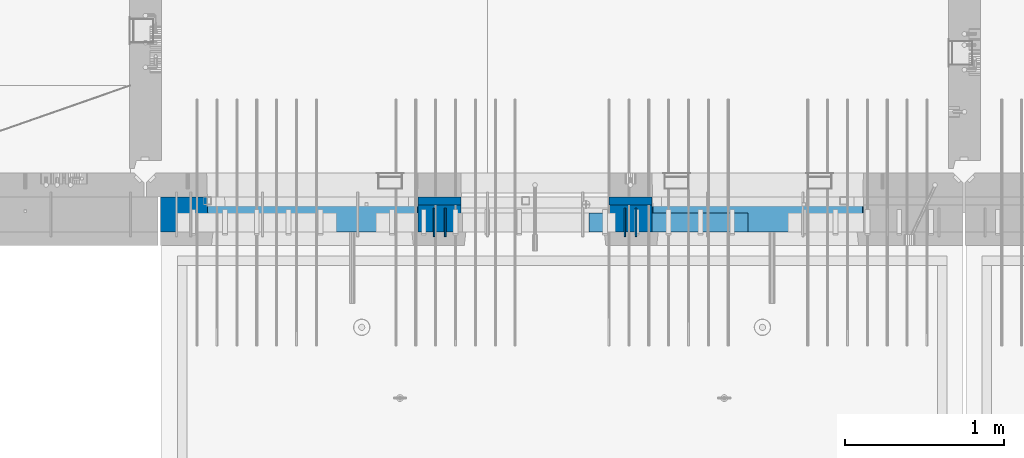
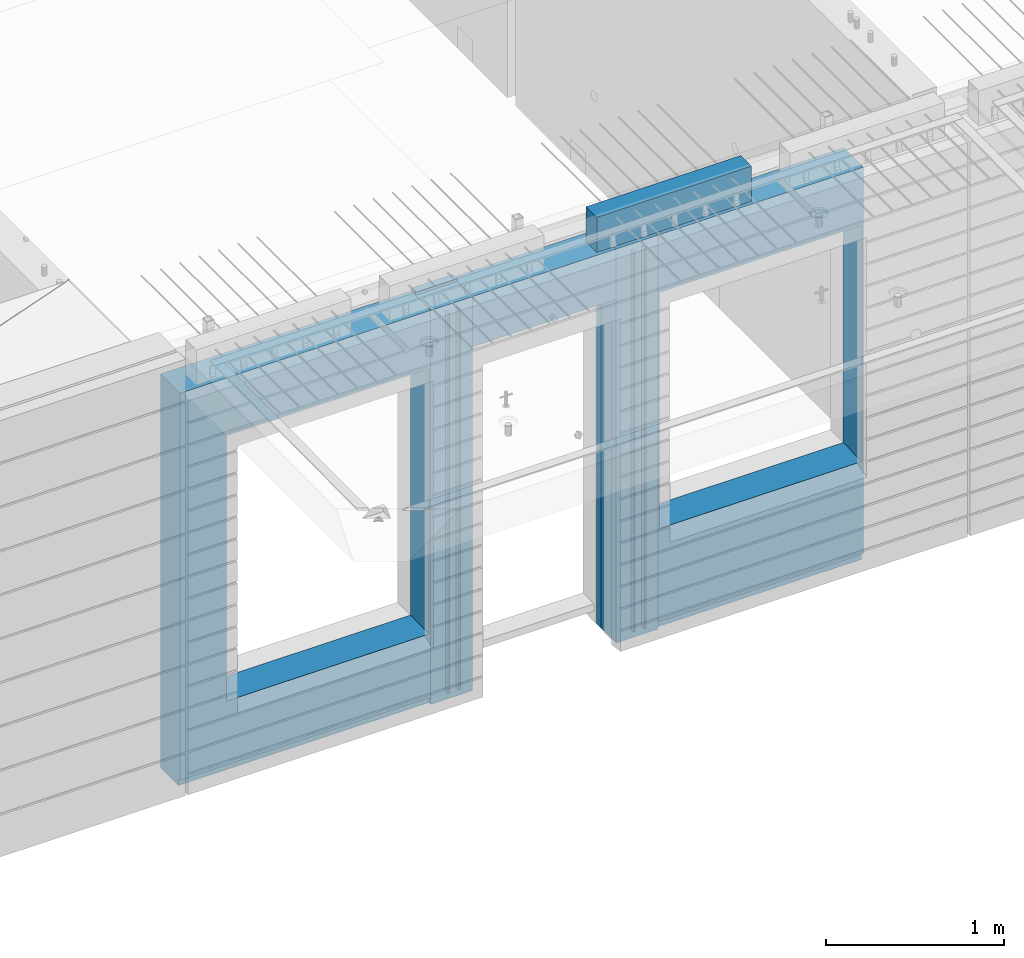
# One storey, part 219 of 334: 10 walls, 3 elements without a shape of their own.
"""IFC2X3 building model written with IfcOpenShell, lengths in millimetres."""

from ifc_helpers import new_model, si_unit, frame, origin_with_axes, place, context, subcontext, project, spatial, faceted_brep, material, type_object, element, aggregate, save


model = new_model("IFC2X3")

# Units and contexts
model_context = context("Model", 3, precision=1e-05, world=origin_with_axes())
body_context = subcontext(model_context, "Body", "Model", "MODEL_VIEW")
ifc_project = project(units=[si_unit("LENGTHUNIT", "METRE", prefix="MILLI"), si_unit("AREAUNIT", "SQUARE_METRE"), si_unit("VOLUMEUNIT", "CUBIC_METRE"), si_unit("MASSUNIT", "GRAM", prefix="KILO"), si_unit("TIMEUNIT", "SECOND"), si_unit("PLANEANGLEUNIT", "RADIAN"), si_unit("SOLIDANGLEUNIT", "STERADIAN"), si_unit("THERMODYNAMICTEMPERATUREUNIT", "DEGREE_CELSIUS"), si_unit("LUMINOUSINTENSITYUNIT", "LUMEN")], contexts=[model_context])

# Site, building, storey
site_placement = place(None, origin_with_axes())
site = spatial("IfcSite", under=ifc_project, at=site_placement, CompositionType="ELEMENT")
building_placement = place(site_placement, origin_with_axes())
building = spatial("IfcBuilding", under=site, at=building_placement, CompositionType="ELEMENT")
storey_placement = place(building_placement, origin_with_axes())
storey = spatial("IfcBuildingStorey", under=building, at=storey_placement, Name="3", CompositionType="ELEMENT", Elevation=0.0)

# Assembly, walls
assembly_1_placement = place(storey_placement, origin_with_axes())
assembly_1 = element("IfcElementAssembly", 1, at=assembly_1_placement, inside=storey, AssemblyPlace="NOTDEFINED", PredefinedType="REINFORCEMENT_UNIT")
ifc_material_1 = material(Name="Undefined")
wall_type_1 = type_object("IfcWallType", PredefinedType="NOTDEFINED")
wall_1_placement = place(assembly_1_placement, frame((18475.0, 7780.0, 89115.0), z_axis=(0.0, 0.0, 1.0), x_axis=(0.0, -1.0, 0.0)))
wall_1 = element("IfcWall", 2, at=wall_1_placement, type_object=wall_type_1, material=ifc_material_1, Name="(PD)", context=body_context, shape_type="Brep", body=[
    faceted_brep([(0.0, 5.0, -1300.0), (0.0, 5.0, 1300.0), (180.0, 5.0, 1300.0), (180.0, 5.0, -1300.0), (0.0, -5.0, 1300.0), (180.0, -5.0, 1300.0), (0.0, -5.0, -1300.0), (180.0, -5.0, -1300.0)], [[[0, 1, 2, 3]], [[1, 4, 5, 2]], [[4, 6, 7, 5]], [[6, 0, 3, 7]], [[5, 7, 3, 2]], [[6, 4, 1, 0]]]),
])
wall_2_placement = place(assembly_1_placement, frame((18545.0, 7780.0, 89115.0), z_axis=(0.0, 0.0, 1.0), x_axis=(0.0, -1.0, 0.0)))
wall_2 = element("IfcWall", 3, at=wall_2_placement, type_object=wall_type_1, material=ifc_material_1, Name="(PD)", context=body_context, shape_type="Brep", body=[
    faceted_brep([(0.0, 5.0, -1300.0), (0.0, 5.0, 1300.0), (180.0, 5.0, 1300.0), (180.0, 5.0, -1300.0), (0.0, -5.0, 1300.0), (180.0, -5.0, 1300.0), (0.0, -5.0, -1300.0), (180.0, -5.0, -1300.0)], [[[0, 1, 2, 3]], [[1, 4, 5, 2]], [[4, 6, 7, 5]], [[6, 0, 3, 7]], [[5, 7, 3, 2]], [[6, 4, 1, 0]]]),
])
wall_3_placement = place(assembly_1_placement, frame((19675.0, 7779.99999999997, 89115.0), z_axis=(0.0, 0.0, 1.0), x_axis=(0.0, -1.0, 0.0)))
wall_3 = element("IfcWall", 4, at=wall_3_placement, type_object=wall_type_1, material=ifc_material_1, Name="(PD)", context=body_context, shape_type="Brep", body=[
    faceted_brep([(0.0, 5.0, -1300.0), (0.0, 5.0, 1300.0), (180.0, 5.0, 1300.0), (180.0, 5.0, -1300.0), (0.0, -5.0, 1300.0), (180.0, -5.0, 1300.0), (0.0, -5.0, -1300.0), (180.0, -5.0, -1300.0)], [[[0, 1, 2, 3]], [[1, 4, 5, 2]], [[4, 6, 7, 5]], [[6, 0, 3, 7]], [[5, 7, 3, 2]], [[6, 4, 1, 0]]]),
])
wall_4_placement = place(assembly_1_placement, frame((19745.0, 7780.0, 89115.0), z_axis=(0.0, 0.0, 1.0), x_axis=(0.0, -1.0, 0.0)))
wall_4 = element("IfcWall", 5, at=wall_4_placement, type_object=wall_type_1, material=ifc_material_1, Name="(PD)", context=body_context, shape_type="Brep", body=[
    faceted_brep([(0.0, 5.0, -1300.0), (0.0, 5.0, 1300.0), (180.0, 5.0, 1300.0), (180.0, 5.0, -1300.0), (0.0, -5.0, 1300.0), (180.0, -5.0, 1300.0), (0.0, -5.0, -1300.0), (180.0, -5.0, -1300.0)], [[[0, 1, 2, 3]], [[1, 4, 5, 2]], [[4, 6, 7, 5]], [[6, 0, 3, 7]], [[5, 7, 3, 2]], [[6, 4, 1, 0]]]),
])

# Assemblies, wall
assembly_2_placement = place(storey_placement, origin_with_axes())
assembly_2 = element("IfcElementAssembly", 6, at=assembly_2_placement, inside=storey, AssemblyPlace="NOTDEFINED", PredefinedType="REINFORCEMENT_UNIT")
assembly_3_placement = place(assembly_2_placement, origin_with_axes())
assembly_3 = element("IfcElementAssembly", 7, at=assembly_3_placement, Name="Steel Assembly", AssemblyPlace="NOTDEFINED", PredefinedType="NOTDEFINED")
aggregate(assembly_2, [assembly_3])
ifc_material_2 = material()
wall_type_2 = type_object("IfcWallType", PredefinedType="NOTDEFINED")
wall_5_placement = place(assembly_3_placement, frame((19449.9998568133, 7690.00021946163, 90590.0), z_axis=(0.0, 0.0, 1.0), x_axis=(1.0, 0.0, 0.0)))
wall_5 = element("IfcWall", 8, at=wall_5_placement, type_object=wall_type_2, material=ifc_material_2, context=body_context, shape_type="Brep", body=[
    faceted_brep([(0.0, 60.0, -120.0), (0.0, 60.0, 120.0), (1000.0, 60.0, 120.0), (1000.0, 60.0, -120.0), (0.0, -60.0, 120.0), (1000.0, -60.0, 120.0), (0.0, -60.0, -120.0), (1000.0, -60.0, -120.0)], [[[0, 1, 2, 3]], [[1, 4, 5, 2]], [[4, 6, 7, 5]], [[6, 0, 3, 7]], [[5, 7, 3, 2]], [[6, 4, 1, 0]]]),
])
aggregate(assembly_3, [wall_5])

# Wall
ifc_material_3 = material(Name="CONCRETE/C35/45")
wall_type_3 = type_object("IfcWallType", PredefinedType="NOTDEFINED")
wall_6_placement = place(assembly_1_placement, frame((18645.0200381475, 7825.0, 89112.5), z_axis=(0.0, 0.0, 1.0), x_axis=(-1.0, 3.00000001838171e-08, 0.0)))
wall_6 = element("IfcWall", 9, at=wall_6_placement, type_object=wall_type_3, material=ifc_material_3, context=body_context, shape_type="Brep", body=[
    faceted_brep([(0.0, 25.0, -1357.5), (0.0, 25.0, 1357.5), (270.001908754726, 25.0, 1357.5), (270.001908754726, 25.0, -1357.5), (0.0, -25.0, 1357.5), (270.001908754726, -25.0, 1357.5), (0.0, -25.0, -1357.5), (270.001908754726, -25.0, -1357.5)], [[[0, 1, 2, 3]], [[1, 4, 5, 2]], [[4, 6, 7, 5]], [[6, 0, 3, 7]], [[5, 7, 3, 2]], [[6, 4, 1, 0]]]),
])

wall_7_placement = place(assembly_1_placement, frame((19845.0100381475, 7825.0, 89112.5), z_axis=(0.0, 0.0, 1.0), x_axis=(-1.0, 3.00000001838171e-08, 0.0)))
wall_7 = element("IfcWall", 10, at=wall_7_placement, type_object=wall_type_3, material=ifc_material_3, context=body_context, shape_type="Brep", body=[
    faceted_brep([(0.0, 25.0, -1357.5), (0.0, 25.0, 1357.5), (270.001908754726, 25.0, 1357.5), (270.001908754726, 25.0, -1357.5), (0.0, -25.0, 1357.5), (270.001908754726, -25.0, 1357.5), (0.0, -25.0, -1357.5), (270.001908754726, -25.0, -1357.5)], [[[0, 1, 2, 3]], [[1, 4, 5, 2]], [[4, 6, 7, 5]], [[6, 0, 3, 7]], [[5, 7, 3, 2]], [[6, 4, 1, 0]]]),
])

ifc_material_4 = material(Name="SPU")
wall_type_4 = type_object("IfcWallType", PredefinedType="NOTDEFINED")
wall_8_placement = place(assembly_1_placement, frame((18645.0100381475, 7715.0, 89102.5), z_axis=(0.0, 0.0, 1.0), x_axis=(-1.0, 3.00000001838171e-08, 0.0)))
wall_8 = element("IfcWall", 11, at=wall_8_placement, type_object=wall_type_4, material=ifc_material_4, context=body_context, shape_type="Brep", body=[
    faceted_brep([(0.0, 85.0, -1347.5), (0.0, 85.0, 1347.5), (270.001908754726, 85.0, 1347.5), (270.001908754726, 85.0, -1347.5), (0.0, -85.0, 1347.5), (270.001908754726, -85.0, 1347.5), (0.0, -85.0, -1347.5), (270.001908754726, -85.0, -1347.5)], [[[0, 1, 2, 3]], [[1, 4, 5, 2]], [[4, 6, 7, 5]], [[6, 0, 3, 7]], [[5, 7, 3, 2]], [[6, 4, 1, 0]]]),
])

wall_9_placement = place(assembly_1_placement, frame((19845.0100381475, 7715.0, 89102.5), z_axis=(0.0, 0.0, 1.0), x_axis=(-1.0, 3.00000001838171e-08, 0.0)))
wall_9 = element("IfcWall", 12, at=wall_9_placement, type_object=wall_type_4, material=ifc_material_4, context=body_context, shape_type="Brep", body=[
    faceted_brep([(0.0, 85.0, -1347.5), (0.0, 85.0, 1347.5), (270.001908754726, 85.0, 1347.5), (270.001908754726, 85.0, -1347.5), (0.0, -85.0, 1347.5), (270.001908754726, -85.0, 1347.5), (0.0, -85.0, -1347.5), (270.001908754726, -85.0, -1347.5)], [[[0, 1, 2, 3]], [[1, 4, 5, 2]], [[4, 6, 7, 5]], [[6, 0, 3, 7]], [[5, 7, 3, 2]], [[6, 4, 1, 0]]]),
])

ifc_material_5 = material(Name="COS5gt")
wall_type_5 = type_object("IfcWallType", PredefinedType="NOTDEFINED")
wall_10_placement = place(assembly_1_placement, frame((21175.0, 7740.0, 89102.5), z_axis=(0.0, 0.0, 1.0), x_axis=(-1.0, 3.00000001838171e-08, 0.0)))
wall_10 = element("IfcWall", 13, at=wall_10_placement, type_object=wall_type_5, material=ifc_material_5, context=body_context, shape_type="Brep", body=[
    faceted_brep([(4420.0, -110.0, 1347.5), (4420.0, 110.0, 1347.5), (2799.99187060721, 110.0, 1347.5), (2799.99187060721, -10.0, 1347.5), (2799.9818706072, -110.0, 1347.5), (4420.0, 110.0, -1297.5), (4420.0, 90.0, -1297.5), (2799.99187060721, 90.0, -1297.5), (2799.99187060721, 110.0, -1297.5), (4420.0, -110.0, -1347.5), (4420.0, 90.0, -1347.5), (2799.99187060721, 90.0, -1347.5), (2799.99187060721, -10.0, -1347.5), (2809.99937278789, 110.0, -862.5), (2839.99937278789, 110.0, -862.5), (4089.99937278789, 110.0, -862.5), (4119.99937278789, 110.0, -862.5), (4119.99937278789, 110.0, -857.5), (4119.99937278789, 110.0, 952.5), (2809.99937278789, 110.0, 952.5), (2809.99937278789, 110.0, -857.5), (2804.05342684194, -110.0, -868.445945945947), (2804.05342684194, -109.999999999999, 958.445945945947), (4125.94531873383, -110.0, -868.445945945947), (4125.94531873383, -109.999999999999, 958.445945945947), (2799.9818706072, -110.0, -1347.5), (1329.98996185248, -110.0, 1347.5), (1329.98996185248, -110.0, -1347.5), (1329.98996185248, -10.0, -1347.5), (1329.98996185248, -10.0, 1347.5), (0.0, -110.0, -1347.5), (0.0, 90.0, -1347.5), (1329.98996185248, 90.0, -1347.5), (0.0, 90.0, -1297.5), (0.0, 110.0, -1297.5), (1329.98996185248, 110.0, -1297.5), (1329.98996185248, 90.0, -1297.5), (0.0, -110.0, 1347.5), (0.0, 110.0, 1347.5), (1329.98996185248, 110.0, 1347.5), (10.0001357273395, 110.0, -662.5), (40.0001357273395, 110.0, -662.5), (1290.00013572734, 110.0, -662.5), (1320.00013572734, 110.0, -662.5), (1320.00013572734, 110.0, -657.5), (1320.00013572734, 110.0, 952.5), (10.0001357273395, 110.0, 952.5), (10.0001357273395, 110.0, -657.5), (4.05418978139278, -110.0, -668.445945945947), (4.05418978139278, -109.999999999999, 958.445945945947), (1325.94608167329, -110.0, -668.445945945947), (1325.94608167329, -109.999999999999, 958.445945945947), (1600.00051719707, -109.999999999999, 1002.5), (1599.99187060721, -110.0, 1347.5), (1599.99187060721, -10.0, 1347.5), (1600.00051719707, -10.0, 1002.5), (1600.00051719707, 110.0, 1002.5), (1599.99187060721, 110.0, 1347.5), (2529.98996185248, 110.0, 1347.5), (2529.98996185248, 110.0, 1002.5), (2529.98996185248, -10.0, 1347.5), (2529.98996185248, -10.0, 1002.5), (2529.97996185248, -110.0, 1347.5), (2529.97996185248, -109.999999999999, 1002.5)], [[[0, 1, 2, 3, 4]], [[5, 6, 7, 8]], [[1, 0, 9, 10, 6, 5]], [[6, 10, 11, 7]], [[2, 8, 7, 11, 12, 3]], [[1, 5, 8, 2], [13, 14, 15, 16, 17, 18, 19, 20]], [[21, 13, 20, 19, 22]], [[23, 16, 15, 14, 13, 21]], [[17, 16, 23, 24, 18]], [[22, 19, 18, 24]], [[9, 0, 4, 25], [23, 21, 22, 24]], [[11, 10, 9, 25, 12]], [[4, 3, 12, 25]], [[26, 27, 28, 29]], [[27, 30, 31, 32, 28]], [[33, 34, 35, 36]], [[31, 33, 36, 32]], [[30, 37, 38, 34, 33, 31]], [[38, 37, 26, 29, 39]], [[29, 28, 32, 36, 35, 39]], [[34, 38, 39, 35], [40, 41, 42, 43, 44, 45, 46, 47]], [[48, 40, 47, 46, 49]], [[50, 43, 42, 41, 40, 48]], [[44, 43, 50, 51, 45]], [[49, 46, 45, 51]], [[37, 30, 27, 26], [50, 48, 49, 51]], [[52, 53, 54, 55]], [[56, 57, 58, 59]], [[59, 58, 60, 61]], [[62, 63, 61, 60]], [[53, 52, 63, 62]], [[56, 59, 61, 63, 52, 55]], [[54, 57, 56, 55]], [[62, 60, 58, 57, 54, 53]]]),
])

aggregate(assembly_1, [wall_6, wall_8, wall_9, wall_1, wall_2, wall_7, wall_3, wall_4, wall_10])

save(model, "model.ifc")
